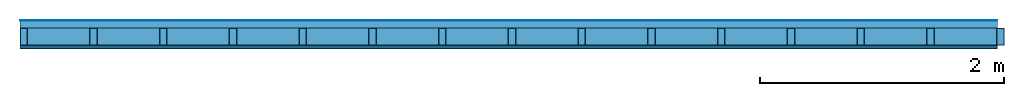
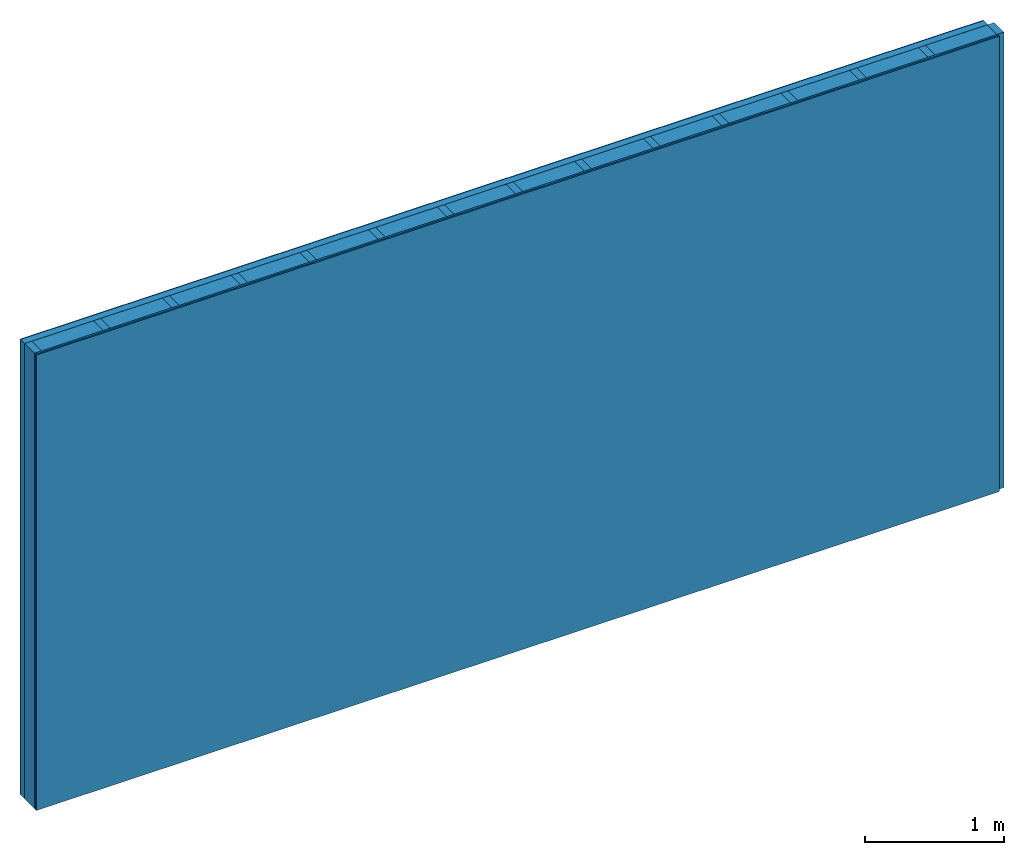
# One storey: 5 plates, 2 members, 1 element without a shape of its own.
"""IFC4 building model written with IfcOpenShell, lengths in metres."""

from ifc_helpers import new_model, si_unit, derived_unit, direction, frame, frame_2d, origin, origin_with_axes, place, context, project, spatial, rectangle, extrude, material, layer, layer_set, type_object, element, aggregate, save


model = new_model("IFC4")

# Units and contexts
plan_context = context("Plan", 3, precision=1e-05, world=origin(), true_north=direction((0.0, 1.0)))
model_context = context("Model", 3, precision=1e-05, world=origin(), true_north=direction((0.0, 1.0)))
ifc_project = project(units=[si_unit("LENGTHUNIT", "METRE"), derived_unit("SOUNDPRESSUREUNIT", [(si_unit("PRESSUREUNIT", "PASCAL", prefix="MICRO"), 0)]), si_unit("ENERGYUNIT", "JOULE", prefix="MEGA"), si_unit("MASSUNIT", "GRAM", prefix="KILO"), derived_unit("THERMALTRANSMITTANCEUNIT", [(si_unit("POWERUNIT", "WATT"), 1), (si_unit("AREAUNIT", "SQUARE_METRE"), -1), (si_unit("THERMODYNAMICTEMPERATUREUNIT", "KELVIN"), -1)]), derived_unit("AREADENSITYUNIT", [(si_unit("MASSUNIT", "GRAM", prefix="KILO"), 1), (si_unit("AREAUNIT", "SQUARE_METRE"), -1)]), derived_unit("USERDEFINED", [(si_unit("ENERGYUNIT", "JOULE", prefix="MEGA"), 1), (si_unit("AREAUNIT", "SQUARE_METRE"), -1)])], contexts=[plan_context, model_context])

# Site, building, storey
site = spatial("IfcSite", under=ifc_project)
building_placement = place(None, origin())
building = spatial("IfcBuilding", under=site, at=building_placement)
storey_placement = place(building_placement, origin())
storey = spatial("IfcBuildingStorey", under=building, at=storey_placement)

# Wall, members, plates
ifc_material_1 = material()
ifc_layer_1 = layer(ifc_material_1, 0.002, Name="Surface 2")
ifc_material_2 = material(Name="Mineral flush, adhesive and reinforcement fabric")
ifc_layer_2 = layer(ifc_material_2, 0.005, Name="Surface 1")
ifc_material_3 = material(Category="10.009")
ifc_layer_3 = layer(ifc_material_3, 0.06, Name="Cover 2nd layer")
ifc_material_4 = material(Name="of the art")
ifc_layer_4 = layer(ifc_material_4, 0.0, Name="Bond")
ifc_layer_5 = layer(None, 0.14, Name="Support")
ifc_material_5 = material(Name="Rigid, of the art")
ifc_layer_6 = layer(ifc_material_5, 0.0, Name="Bond")
ifc_material_6 = material(Name="LivingBoard face P5", Category="07.015")
ifc_layer_7 = layer(ifc_material_6, 0.015, Name="1st layer")
ifc_material_7 = material(Category="03.007")
ifc_layer_8 = layer(ifc_material_7, 0.0125, Name="2nd layer")
ifc_layer_set = layer_set([ifc_layer_1, ifc_layer_2, ifc_layer_3, ifc_layer_4, ifc_layer_5, ifc_layer_6, ifc_layer_7, ifc_layer_8])
wall_type = type_object("IfcWallType", Name="D1232", PredefinedType="NOTDEFINED", material=ifc_layer_set)
wall_placement = place(None, frame((0.0, 0.0, 0.0), z_axis=(0.0, -1.0, 0.0), x_axis=(1.0, 0.0, 0.0)))
wall = element("IfcWall", 1, at=wall_placement, inside=storey, type_object=wall_type, material=ifc_layer_set, Name="Wall #1")
ifc_material_8 = material()
member_1_placement = place(wall_placement, origin())
member_1 = element("IfcMember", 2, at=member_1_placement, material=ifc_material_8, Name="Support", context=plan_context, shape_type="SweptSolid", body=[
    extrude(rectangle(XDim=0.06, YDim=0.14, at=frame_2d((0.03, 0.07), x_axis=(1.0, 0.0))), frame((0.0, 4.0, 0.067), z_axis=(0.0, -1.0, 0.0), x_axis=(1.0, 0.0, 0.0)), (0.0, 0.0, 1.0), 4.0),
    extrude(rectangle(XDim=0.06, YDim=0.14, at=frame_2d((0.03, 0.07), x_axis=(1.0, 0.0))), frame((0.571, 4.0, 0.067), z_axis=(0.0, -1.0, 0.0), x_axis=(1.0, 0.0, 0.0)), (0.0, 0.0, 1.0), 4.0),
    extrude(rectangle(XDim=0.06, YDim=0.14, at=frame_2d((0.03, 0.07), x_axis=(1.0, 0.0))), frame((1.142, 4.0, 0.067), z_axis=(0.0, -1.0, 0.0), x_axis=(1.0, 0.0, 0.0)), (0.0, 0.0, 1.0), 4.0),
    extrude(rectangle(XDim=0.06, YDim=0.14, at=frame_2d((0.03, 0.07), x_axis=(1.0, 0.0))), frame((1.713, 4.0, 0.067), z_axis=(0.0, -1.0, 0.0), x_axis=(1.0, 0.0, 0.0)), (0.0, 0.0, 1.0), 4.0),
    extrude(rectangle(XDim=0.06, YDim=0.14, at=frame_2d((0.03, 0.07), x_axis=(1.0, 0.0))), frame((2.284, 4.0, 0.067), z_axis=(0.0, -1.0, 0.0), x_axis=(1.0, 0.0, 0.0)), (0.0, 0.0, 1.0), 4.0),
    extrude(rectangle(XDim=0.06, YDim=0.14, at=frame_2d((0.03, 0.07), x_axis=(1.0, 0.0))), frame((2.855, 4.0, 0.067), z_axis=(0.0, -1.0, 0.0), x_axis=(1.0, 0.0, 0.0)), (0.0, 0.0, 1.0), 4.0),
    extrude(rectangle(XDim=0.06, YDim=0.14, at=frame_2d((0.03, 0.07), x_axis=(1.0, 0.0))), frame((3.426, 4.0, 0.067), z_axis=(0.0, -1.0, 0.0), x_axis=(1.0, 0.0, 0.0)), (0.0, 0.0, 1.0), 4.0),
    extrude(rectangle(XDim=0.06, YDim=0.14, at=frame_2d((0.03, 0.07), x_axis=(1.0, 0.0))), frame((3.997, 4.0, 0.067), z_axis=(0.0, -1.0, 0.0), x_axis=(1.0, 0.0, 0.0)), (0.0, 0.0, 1.0), 4.0),
    extrude(rectangle(XDim=0.06, YDim=0.14, at=frame_2d((0.03, 0.07), x_axis=(1.0, 0.0))), frame((4.568, 4.0, 0.067), z_axis=(0.0, -1.0, 0.0), x_axis=(1.0, 0.0, 0.0)), (0.0, 0.0, 1.0), 4.0),
    extrude(rectangle(XDim=0.06, YDim=0.14, at=frame_2d((0.03, 0.07), x_axis=(1.0, 0.0))), frame((5.139, 4.0, 0.067), z_axis=(0.0, -1.0, 0.0), x_axis=(1.0, 0.0, 0.0)), (0.0, 0.0, 1.0), 4.0),
    extrude(rectangle(XDim=0.06, YDim=0.14, at=frame_2d((0.03, 0.07), x_axis=(1.0, 0.0))), frame((5.71, 4.0, 0.067), z_axis=(0.0, -1.0, 0.0), x_axis=(1.0, 0.0, 0.0)), (0.0, 0.0, 1.0), 4.0),
    extrude(rectangle(XDim=0.06, YDim=0.14, at=frame_2d((0.03, 0.07), x_axis=(1.0, 0.0))), frame((6.281, 4.0, 0.067), z_axis=(0.0, -1.0, 0.0), x_axis=(1.0, 0.0, 0.0)), (0.0, 0.0, 1.0), 4.0),
    extrude(rectangle(XDim=0.06, YDim=0.14, at=frame_2d((0.03, 0.07), x_axis=(1.0, 0.0))), frame((6.852, 4.0, 0.067), z_axis=(0.0, -1.0, 0.0), x_axis=(1.0, 0.0, 0.0)), (0.0, 0.0, 1.0), 4.0),
    extrude(rectangle(XDim=0.06, YDim=0.14, at=frame_2d((0.03, 0.07), x_axis=(1.0, 0.0))), frame((7.423, 4.0, 0.067), z_axis=(0.0, -1.0, 0.0), x_axis=(1.0, 0.0, 0.0)), (0.0, 0.0, 1.0), 4.0),
    extrude(rectangle(XDim=0.06, YDim=0.14, at=frame_2d((0.03, 0.07), x_axis=(1.0, 0.0))), frame((7.994, 4.0, 0.067), z_axis=(0.0, -1.0, 0.0), x_axis=(1.0, 0.0, 0.0)), (0.0, 0.0, 1.0), 4.0),
])
ifc_material_9 = material(Name="Cellulose insulation")
member_2_placement = place(wall_placement, origin())
member_2 = element("IfcMember", 3, at=member_2_placement, material=ifc_material_9, Name="Cavity", context=plan_context, shape_type="SweptSolid", body=[
    extrude(rectangle(XDim=0.511, YDim=0.14, at=frame_2d((0.2555, 0.07), x_axis=(1.0, 0.0))), frame((0.06, 4.0, 0.067), z_axis=(0.0, -1.0, 0.0), x_axis=(1.0, 0.0, 0.0)), (0.0, 0.0, 1.0), 4.0),
    extrude(rectangle(XDim=0.511, YDim=0.14, at=frame_2d((0.2555, 0.07), x_axis=(1.0, 0.0))), frame((0.631, 4.0, 0.067), z_axis=(0.0, -1.0, 0.0), x_axis=(1.0, 0.0, 0.0)), (0.0, 0.0, 1.0), 4.0),
    extrude(rectangle(XDim=0.511, YDim=0.14, at=frame_2d((0.2555, 0.07), x_axis=(1.0, 0.0))), frame((1.202, 4.0, 0.067), z_axis=(0.0, -1.0, 0.0), x_axis=(1.0, 0.0, 0.0)), (0.0, 0.0, 1.0), 4.0),
    extrude(rectangle(XDim=0.511, YDim=0.14, at=frame_2d((0.2555, 0.07), x_axis=(1.0, 0.0))), frame((1.773, 4.0, 0.067), z_axis=(0.0, -1.0, 0.0), x_axis=(1.0, 0.0, 0.0)), (0.0, 0.0, 1.0), 4.0),
    extrude(rectangle(XDim=0.511, YDim=0.14, at=frame_2d((0.2555, 0.07), x_axis=(1.0, 0.0))), frame((2.344, 4.0, 0.067), z_axis=(0.0, -1.0, 0.0), x_axis=(1.0, 0.0, 0.0)), (0.0, 0.0, 1.0), 4.0),
    extrude(rectangle(XDim=0.511, YDim=0.14, at=frame_2d((0.2555, 0.07), x_axis=(1.0, 0.0))), frame((2.915, 4.0, 0.067), z_axis=(0.0, -1.0, 0.0), x_axis=(1.0, 0.0, 0.0)), (0.0, 0.0, 1.0), 4.0),
    extrude(rectangle(XDim=0.511, YDim=0.14, at=frame_2d((0.2555, 0.07), x_axis=(1.0, 0.0))), frame((3.486, 4.0, 0.067), z_axis=(0.0, -1.0, 0.0), x_axis=(1.0, 0.0, 0.0)), (0.0, 0.0, 1.0), 4.0),
    extrude(rectangle(XDim=0.511, YDim=0.14, at=frame_2d((0.2555, 0.07), x_axis=(1.0, 0.0))), frame((4.057, 4.0, 0.067), z_axis=(0.0, -1.0, 0.0), x_axis=(1.0, 0.0, 0.0)), (0.0, 0.0, 1.0), 4.0),
    extrude(rectangle(XDim=0.511, YDim=0.14, at=frame_2d((0.2555, 0.07), x_axis=(1.0, 0.0))), frame((4.628, 4.0, 0.067), z_axis=(0.0, -1.0, 0.0), x_axis=(1.0, 0.0, 0.0)), (0.0, 0.0, 1.0), 4.0),
    extrude(rectangle(XDim=0.511, YDim=0.14, at=frame_2d((0.2555, 0.07), x_axis=(1.0, 0.0))), frame((5.199, 4.0, 0.067), z_axis=(0.0, -1.0, 0.0), x_axis=(1.0, 0.0, 0.0)), (0.0, 0.0, 1.0), 4.0),
    extrude(rectangle(XDim=0.511, YDim=0.14, at=frame_2d((0.2555, 0.07), x_axis=(1.0, 0.0))), frame((5.77, 4.0, 0.067), z_axis=(0.0, -1.0, 0.0), x_axis=(1.0, 0.0, 0.0)), (0.0, 0.0, 1.0), 4.0),
    extrude(rectangle(XDim=0.511, YDim=0.14, at=frame_2d((0.2555, 0.07), x_axis=(1.0, 0.0))), frame((6.341, 4.0, 0.067), z_axis=(0.0, -1.0, 0.0), x_axis=(1.0, 0.0, 0.0)), (0.0, 0.0, 1.0), 4.0),
    extrude(rectangle(XDim=0.511, YDim=0.14, at=frame_2d((0.2555, 0.07), x_axis=(1.0, 0.0))), frame((6.912, 4.0, 0.067), z_axis=(0.0, -1.0, 0.0), x_axis=(1.0, 0.0, 0.0)), (0.0, 0.0, 1.0), 4.0),
    extrude(rectangle(XDim=0.511, YDim=0.14, at=frame_2d((0.2555, 0.07), x_axis=(1.0, 0.0))), frame((7.483, 4.0, 0.067), z_axis=(0.0, -1.0, 0.0), x_axis=(1.0, 0.0, 0.0)), (0.0, 0.0, 1.0), 4.0),
])
plate_1_placement = place(wall_placement, origin())
plate_1 = element("IfcPlate", 4, at=plate_1_placement, material=ifc_material_1, Name="Surface 2", context=plan_context, shape_type="SweptSolid", body=[
    extrude(rectangle(XDim=8.0, YDim=4.0, at=frame_2d((4.0, 2.0), x_axis=(1.0, 0.0))), origin_with_axes(), (0.0, 0.0, 1.0), 0.002),
])
plate_2_placement = place(wall_placement, origin())
plate_2 = element("IfcPlate", 5, at=plate_2_placement, material=ifc_material_2, Name="Surface 1", context=plan_context, shape_type="SweptSolid", body=[
    extrude(rectangle(XDim=8.0, YDim=4.0, at=frame_2d((4.0, 2.0), x_axis=(1.0, 0.0))), frame((0.0, 0.0, 0.002), z_axis=(0.0, 0.0, 1.0), x_axis=(1.0, 0.0, 0.0)), (0.0, 0.0, 1.0), 0.005),
])
plate_3_placement = place(wall_placement, origin())
plate_3 = element("IfcPlate", 6, at=plate_3_placement, material=ifc_material_3, Name="Cover 2nd layer", context=plan_context, shape_type="SweptSolid", body=[
    extrude(rectangle(XDim=8.0, YDim=4.0, at=frame_2d((4.0, 2.0), x_axis=(1.0, 0.0))), frame((0.0, 0.0, 0.007), z_axis=(0.0, 0.0, 1.0), x_axis=(1.0, 0.0, 0.0)), (0.0, 0.0, 1.0), 0.06),
])
plate_4_placement = place(wall_placement, origin())
plate_4 = element("IfcPlate", 7, at=plate_4_placement, material=ifc_material_6, Name="1st layer", context=plan_context, shape_type="SweptSolid", body=[
    extrude(rectangle(XDim=8.0, YDim=4.0, at=frame_2d((4.0, 2.0), x_axis=(1.0, 0.0))), frame((0.0, 0.0, 0.207), z_axis=(0.0, 0.0, 1.0), x_axis=(1.0, 0.0, 0.0)), (0.0, 0.0, 1.0), 0.015),
])
plate_5_placement = place(wall_placement, origin())
plate_5 = element("IfcPlate", 8, at=plate_5_placement, material=ifc_material_7, Name="2nd layer", context=plan_context, shape_type="SweptSolid", body=[
    extrude(rectangle(XDim=8.0, YDim=4.0, at=frame_2d((4.0, 2.0), x_axis=(1.0, 0.0))), frame((0.0, 0.0, 0.222), z_axis=(0.0, 0.0, 1.0), x_axis=(1.0, 0.0, 0.0)), (0.0, 0.0, 1.0), 0.0125),
])
aggregate(wall, [plate_1, plate_2, plate_3, member_1, member_2, plate_4, plate_5])

save(model, "model.ifc")
